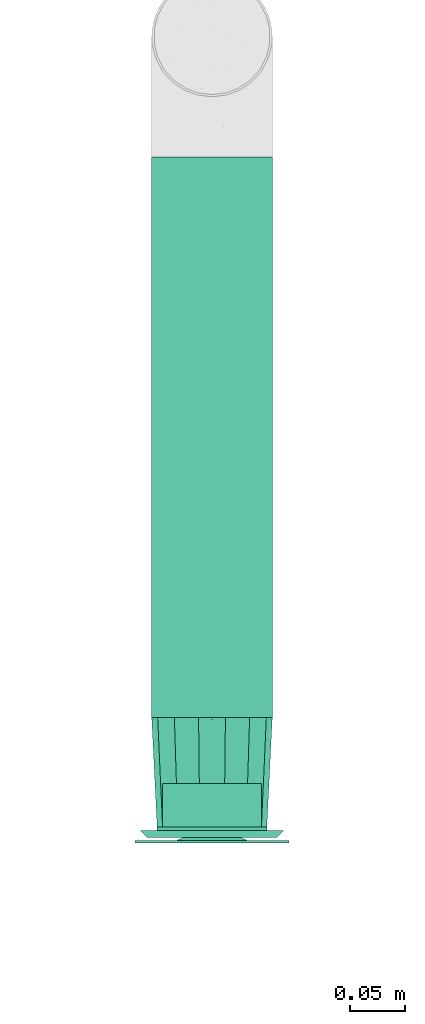
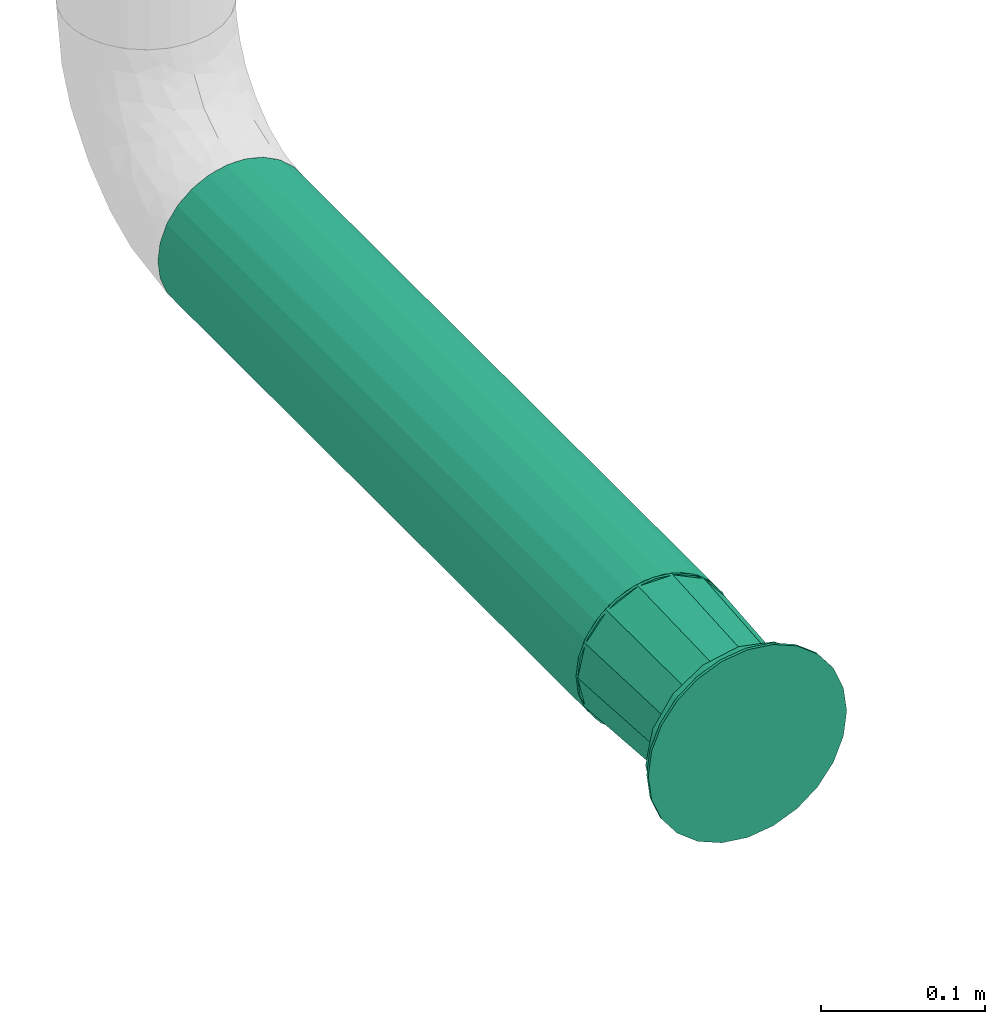
# One storey, part 100 of 115: 1 flow fitting, 1 flow segment, 1 flow terminal.
"""IFC2X3 building model written with IfcOpenShell, lengths in millimetres."""

from ifc_helpers import new_model, entity, si_unit, converted_unit, derived_unit, direction, frame, origin_with_axes, origin_2d_with_axis, place, context, subcontext, project, spatial, hollow_circle, extrude, open_shell, surface_model, source, transform, mapped, material, layer, layer_set, layer_usage, type_object, element, save


model = new_model("IFC2X3")

# Units and contexts
model_context = context("Model", 3, precision=1e-05, world=origin_with_axes(), true_north=direction((0.0, 1.0)))
body_context = subcontext(model_context, "Body", "Model", "MODEL_VIEW")
ifc_project = project(units=[si_unit("AREAUNIT", "SQUARE_METRE"), si_unit("VOLUMEUNIT", "CUBIC_METRE", prefix="DECI"), si_unit("TIMEUNIT", "SECOND"), si_unit("THERMODYNAMICTEMPERATUREUNIT", "DEGREE_CELSIUS"), si_unit("PRESSUREUNIT", "PASCAL"), si_unit("MASSUNIT", "GRAM", prefix="KILO"), si_unit("LENGTHUNIT", "METRE", prefix="MILLI"), si_unit("POWERUNIT", "WATT"), si_unit("ELECTRICCURRENTUNIT", "AMPERE"), si_unit("ELECTRICVOLTAGEUNIT", "VOLT"), derived_unit("VOLUMETRICFLOWRATEUNIT", [(si_unit("VOLUMEUNIT", "CUBIC_METRE", prefix="DECI"), 1), (si_unit("TIMEUNIT", "SECOND"), -1)]), derived_unit("LINEARVELOCITYUNIT", [(si_unit("LENGTHUNIT", "METRE"), 1), (si_unit("TIMEUNIT", "SECOND"), -1)]), derived_unit("MASSDENSITYUNIT", [(si_unit("MASSUNIT", "GRAM", prefix="KILO"), 1), (si_unit("VOLUMEUNIT", "CUBIC_METRE"), -1)]), converted_unit("PLANEANGLEUNIT", "DEGREE", entity("IfcRatioMeasure", 0.01745), si_unit("PLANEANGLEUNIT", "RADIAN"), dimensions=[0, 0, 0, 0, 0, 0, 0])], contexts=[model_context])

# Site, building, storey
site_placement = place(None, origin_with_axes())
site = spatial("IfcSite", under=ifc_project, at=site_placement, CompositionType="ELEMENT")
building_placement = place(site_placement, origin_with_axes())
building = spatial("IfcBuilding", under=site, at=building_placement, Name="mc-building", CompositionType="ELEMENT")
storey_placement = place(building_placement, frame((0.0, 0.0, 2950.0), z_axis=(0.0, 0.0, 1.0), x_axis=(1.0, 0.0, 0.0)))
storey = spatial("IfcBuildingStorey", under=building, at=storey_placement, Name="2. Korrus", CompositionType="ELEMENT", Elevation=2950.0)

# Flow terminal
air_terminal_type = type_object("IfcAirTerminalType", Name="100", PredefinedType="NOTDEFINED")
shared_shape_1 = source(origin_with_axes(), body_context, "Body", "SurfaceModel", [
    surface_model("IfcShellBasedSurfaceModel", [(11.2, 18.11733, -67.61481), (11.2, -18.11733, -67.61481), (11.2, 0.0, -70.0), (11.2, 67.61481, -18.11733), (11.2, 35.0, -60.62178), (11.2, 49.49747, -49.49747), (11.2, 60.62178, -35.0), (11.2, -67.61481, 18.11733), (11.2, -49.49747, -49.49747), (11.2, -67.61481, -18.11733), (11.2, -35.0, -60.62178), (11.2, -60.62178, -35.0), (11.2, -70.0, 0.0), (11.2, 18.11733, 67.61481), (11.2, 70.0, 0.0), (11.2, 67.61481, 18.11733), (11.2, 49.49747, 49.49747), (11.2, 60.62178, 35.0), (11.2, 35.0, 60.62178), (11.2, -49.49747, 49.49747), (11.2, -60.62178, 35.0), (11.2, -35.0, 60.62178), (11.2, -18.11733, 67.61481), (11.2, 0.0, 70.0), (9.2, 18.11733, 67.61481), (9.2, -67.61481, 18.11733), (9.2, 0.0, 70.0), (9.2, 49.49747, 49.49747), (9.2, 35.0, 60.62178), (9.2, 60.62178, 35.0), (9.2, 67.61481, 18.11733), (9.2, -35.0, 60.62178), (9.2, -49.49747, 49.49747), (9.2, -18.11733, 67.61481), (9.2, -60.62178, 35.0), (9.2, -67.61481, -18.11733), (9.2, -70.0, 0.0), (9.2, 67.61481, -18.11733), (9.2, 18.11733, -67.61481), (9.2, 49.49747, -49.49747), (9.2, 60.62178, -35.0), (9.2, 35.0, -60.62178), (9.2, -18.11733, -67.61481), (9.2, -49.49747, -49.49747), (9.2, -60.62178, -35.0), (9.2, -35.0, -60.62178), (9.2, 0.0, -70.0), (9.2, 70.0, 0.0), (9.2, 32.75, 0.0), (9.2, -16.375, 28.36233), (9.2, -28.36233, 16.375), (9.2, 16.375, 28.36233), (9.2, 0.0, 32.75), (9.2, 28.36233, 16.375), (9.2, -32.75, 0.0), (9.2, -16.375, -28.36233), (9.2, 16.375, -28.36233), (9.2, 0.0, -32.75), (9.2, 28.36233, -16.375), (9.2, -28.36233, -16.375), (6.2, -21.19625, -15.39997), (6.2, -21.19625, 15.39997), (6.2, 8.09625, 24.91768), (6.2, -8.09625, 24.91768), (6.2, -26.2, 0.0), (6.2, 21.19625, 15.39997), (6.2, -8.09625, -24.91768), (6.2, 21.19625, -15.39997), (6.2, 8.09625, -24.91768), (6.2, 26.2, 0.0), (9.2, 31.06579, -6.28555), (6.2, 23.69812, -7.69999), (6.2, -14.64625, -20.15883), (9.2, -22.36867, -22.36867), (6.2, -23.69812, -7.69999), (9.2, -31.06579, -6.28555), (6.2, 14.64625, -20.15883), (9.2, 8.1875, -30.55617), (6.2, 0.0, -24.91768), (9.2, 22.36867, -22.36867), (9.2, -8.1875, -30.55617), (9.2, -31.06579, 6.28555), (6.2, -23.69812, 7.69999), (6.2, 14.64625, 20.15883), (9.2, 22.36867, 22.36867), (6.2, 23.69812, 7.69999), (9.2, 31.06579, 6.28555), (6.2, -14.64625, 20.15883), (9.2, -8.1875, 30.55617), (6.2, 0.0, 24.91768), (9.2, -22.36867, 22.36867), (9.2, 8.1875, 30.55617), (6.2, -13.11761, 57.472), (6.2, -36.75472, 46.08897), (6.2, -53.11211, 25.57744), (6.2, 36.75472, 46.08897), (6.2, -58.95, 0.0), (6.2, 13.11761, 57.472), (6.2, 53.11211, 25.57744), (6.2, -53.11211, -25.57744), (6.2, -36.75472, -46.08897), (6.2, -13.11761, -57.472), (6.2, 58.95, 0.0), (6.2, 53.11211, -25.57744), (6.2, 13.11761, -57.472), (6.2, 36.75472, -46.08897), (0.0, -60.51411, 25.06576), (0.0, 0.0, 65.5), (0.0, 25.06576, 60.51411), (0.0, 46.3155, 46.3155), (0.0, 60.51411, 25.06576), (0.0, -46.3155, 46.3155), (0.0, -25.06576, 60.51411), (0.0, 0.0, -65.5), (0.0, -65.5, 0.0), (0.0, 65.5, 0.0), (0.0, 60.51411, -25.06576), (0.0, 46.3155, -46.3155), (0.0, 25.06576, -60.51411), (0.0, -46.3155, -46.3155), (0.0, -60.51411, -25.06576), (0.0, -25.06576, -60.51411), (6.2, 56.03105, -12.78872), (0.0, 53.4148, -35.69063), (0.0, 35.69063, -53.4148), (6.2, 24.93616, -51.78048), (0.0, -12.53288, -63.00706), (6.2, 0.0, -57.472), (0.0, -35.69063, -53.4148), (0.0, 63.00706, -12.53288), (6.2, 44.93342, -35.83321), (6.2, -24.93616, -51.78048), (6.2, -44.93342, -35.83321), (0.0, -53.4148, -35.69063), (0.0, 12.53288, -63.00706), (6.2, -56.03105, -12.78872), (0.0, -63.00706, -12.53288), (6.2, -56.03105, 12.78872), (0.0, -53.4148, 35.69063), (0.0, -35.69063, 53.4148), (6.2, -24.93616, 51.78048), (0.0, 12.53288, 63.00706), (6.2, 0.0, 57.472), (0.0, 35.69063, 53.4148), (0.0, -63.00706, 12.53288), (6.2, -44.93342, 35.83321), (6.2, 24.93616, 51.78048), (6.2, 44.93342, 35.83321), (0.0, 53.4148, 35.69063), (0.0, -12.53288, 63.00706), (6.2, 56.03105, 12.78872), (0.0, 63.00706, 12.53288), (-3.1, 12.94095, 48.29629), (-3.1, -35.35534, 35.35534), (-3.1, 0.0, 50.0), (-3.1, 35.35534, 35.35534), (-3.1, 25.0, 43.30127), (-3.1, -43.30127, 25.0), (-3.1, 43.30127, 25.0), (-3.1, -48.29629, -12.94095), (-3.1, -12.94095, 48.29629), (-3.1, -25.0, 43.30127), (-3.1, -50.0, 0.0), (-3.1, -48.29629, 12.94095), (-3.1, 48.29629, 12.94095), (-3.1, 12.94095, -48.29629), (-3.1, 50.0, 0.0), (-3.1, 48.29629, -12.94095), (-3.1, 35.35534, -35.35534), (-3.1, 43.30127, -25.0), (-3.1, 25.0, -43.30127), (-3.1, 0.0, -50.0), (-3.1, -35.35534, -35.35534), (-3.1, -43.30127, -25.0), (-3.1, -25.0, -43.30127), (-3.1, -12.94095, -48.29629), (0.0, 25.0, -43.30127), (0.0, 0.0, -50.0), (0.0, 12.94095, -48.29629), (0.0, 48.29629, -12.94095), (0.0, 35.35534, -35.35534), (0.0, -25.0, -43.30127), (0.0, 43.30127, -25.0), (0.0, -50.0, 0.0), (0.0, -12.94095, -48.29629), (0.0, -35.35534, -35.35534), (0.0, -48.29629, -12.94095), (0.0, -43.30127, -25.0), (0.0, 50.0, 0.0), (0.0, 43.30127, 25.0), (0.0, 12.94095, 48.29629), (0.0, 35.35534, 35.35534), (0.0, 25.0, 43.30127), (0.0, 0.0, 50.0), (0.0, -35.35534, 35.35534), (0.0, -43.30127, 25.0), (0.0, -48.29629, 12.94095), (0.0, -12.94095, 48.29629), (0.0, -25.0, 43.30127), (0.0, 48.29629, 12.94095), (-43.1, 0.0, 45.0), (-43.1, 11.64686, 43.46666), (-43.1, 22.5, 38.97115), (-43.1, -11.64686, 43.46666), (-43.1, 38.97115, 22.5), (-43.1, 43.46666, 11.64686), (-43.1, 31.81981, 31.81981), (-43.1, -22.5, 38.97115), (-43.1, -43.46666, 11.64686), (-43.1, -31.81981, 31.81981), (-43.1, -38.97115, 22.5), (-43.1, -45.0, 0.0), (-43.1, -43.46666, -11.64686), (-43.1, 45.0, 0.0), (-43.1, 43.46666, -11.64686), (-43.1, 38.97115, -22.5), (-43.1, 31.81981, -31.81981), (-43.1, 22.5, -38.97115), (-43.1, 11.64686, -43.46666), (-43.1, -31.81981, -31.81981), (-43.1, -38.97115, -22.5), (-43.1, -22.5, -38.97115), (-43.1, 0.0, -45.0), (-43.1, -11.64686, -43.46666), (-3.1, 22.5, -38.97115), (-3.1, 0.0, -45.0), (-3.1, 11.64686, -43.46666), (-3.1, 31.81981, -31.81981), (-3.1, -22.5, -38.97115), (-3.1, 38.97115, -22.5), (-3.1, 43.46666, -11.64686), (-3.1, 45.0, 0.0), (-3.1, -45.0, 0.0), (-3.1, -11.64686, -43.46666), (-3.1, -31.81981, -31.81981), (-3.1, -43.46666, -11.64686), (-3.1, -38.97115, -22.5), (-3.1, 0.0, 45.0), (-3.1, 43.46666, 11.64686), (-3.1, 38.97115, 22.5), (-3.1, 22.5, 38.97115), (-3.1, 31.81981, 31.81981), (-3.1, 11.64686, 43.46666), (-3.1, -11.64686, 43.46666), (-3.1, -43.46666, 11.64686), (-3.1, -31.81981, 31.81981), (-3.1, -38.97115, 22.5), (-3.1, -22.5, 38.97115)], [open_shell([[[0, 1, 2]], [[3, 0, 4]], [[5, 6, 3]], [[5, 3, 4]], [[7, 1, 0]], [[8, 7, 9]], [[10, 7, 8]], [[8, 9, 11]], [[12, 9, 7]], [[1, 7, 10]], [[7, 0, 3]], [[13, 14, 15]], [[16, 15, 17]], [[16, 18, 13]], [[16, 13, 15]], [[14, 13, 7]], [[7, 19, 20]], [[19, 7, 21]], [[7, 22, 21]], [[22, 7, 23]], [[7, 13, 23]], [[14, 7, 3]], [[24, 25, 26]], [[27, 24, 28]], [[27, 29, 30]], [[27, 30, 24]], [[25, 24, 30]], [[31, 25, 32]], [[25, 31, 33]], [[32, 25, 34]], [[33, 26, 25]], [[25, 35, 36]], [[25, 30, 37]], [[25, 37, 38]], [[39, 37, 40]], [[39, 41, 38]], [[39, 38, 37]], [[38, 42, 25]], [[35, 43, 44]], [[35, 25, 43]], [[45, 43, 25]], [[42, 45, 25]], [[38, 46, 42]], [[37, 30, 47]], [[35, 9, 36]], [[44, 11, 35]], [[10, 43, 45]], [[44, 43, 8]], [[1, 45, 42]], [[35, 11, 9]], [[9, 12, 36]], [[1, 10, 45]], [[8, 43, 10]], [[8, 11, 44]], [[2, 1, 42]], [[42, 46, 2]], [[38, 0, 46]], [[41, 4, 38]], [[6, 39, 40]], [[41, 39, 5]], [[3, 40, 37]], [[41, 5, 4]], [[4, 0, 38]], [[14, 3, 37]], [[6, 40, 3]], [[6, 5, 39]], [[47, 14, 37]], [[46, 0, 2]], [[30, 15, 47]], [[29, 17, 30]], [[18, 27, 28]], [[29, 27, 16]], [[13, 28, 24]], [[30, 17, 15]], [[15, 14, 47]], [[13, 18, 28]], [[16, 27, 18]], [[16, 17, 29]], [[23, 13, 24]], [[24, 26, 23]], [[33, 22, 26]], [[31, 21, 33]], [[20, 32, 34]], [[31, 32, 19]], [[7, 34, 25]], [[31, 19, 21]], [[21, 22, 33]], [[12, 7, 25]], [[20, 34, 7]], [[20, 19, 32]], [[36, 12, 25]], [[26, 22, 23]], [[48, 49, 50]], [[48, 51, 49]], [[49, 51, 52]], [[53, 51, 48]], [[48, 50, 54]], [[54, 55, 48]], [[56, 55, 57]], [[55, 58, 48]], [[58, 55, 56]], [[55, 54, 59]], [[60, 61, 62]], [[62, 61, 63]], [[64, 61, 60]], [[62, 65, 66]], [[67, 68, 65]], [[66, 60, 62]], [[65, 68, 66]], [[69, 67, 65]], [[69, 48, 70]], [[58, 71, 70]], [[72, 73, 60]], [[59, 74, 60]], [[75, 64, 74]], [[56, 68, 76]], [[72, 66, 55]], [[73, 72, 55]], [[68, 77, 78]], [[64, 75, 54]], [[59, 75, 74]], [[70, 71, 69]], [[67, 79, 76]], [[80, 55, 66]], [[68, 56, 77]], [[56, 76, 79]], [[79, 67, 58]], [[71, 58, 67]], [[80, 78, 57]], [[77, 57, 78]], [[66, 78, 80]], [[59, 60, 73]], [[64, 54, 81]], [[50, 82, 81]], [[83, 84, 65]], [[53, 85, 65]], [[86, 69, 85]], [[49, 63, 87]], [[83, 62, 51]], [[84, 83, 51]], [[63, 88, 89]], [[69, 86, 48]], [[53, 86, 85]], [[81, 82, 64]], [[61, 90, 87]], [[91, 51, 62]], [[63, 49, 88]], [[49, 87, 90]], [[90, 61, 50]], [[82, 50, 61]], [[91, 89, 52]], [[88, 52, 89]], [[62, 89, 91]], [[53, 65, 84]], [[92, 93, 94]], [[95, 94, 96]], [[97, 92, 95]], [[95, 92, 94]], [[96, 98, 95]], [[96, 99, 98]], [[99, 100, 101]], [[101, 102, 98]], [[102, 101, 103]], [[104, 105, 103]], [[101, 104, 103]], [[101, 98, 99]], [[106, 107, 108]], [[109, 110, 108]], [[106, 108, 110]], [[111, 112, 106]], [[106, 112, 107]], [[106, 113, 114]], [[106, 110, 113]], [[115, 116, 117]], [[117, 113, 110]], [[113, 117, 118]], [[114, 119, 120]], [[121, 119, 114]], [[121, 114, 113]], [[115, 117, 110]], [[103, 116, 122]], [[123, 116, 103]], [[124, 125, 118]], [[101, 126, 127]], [[100, 119, 128]], [[102, 122, 129]], [[103, 130, 123]], [[102, 129, 115]], [[113, 127, 126]], [[125, 124, 105]], [[130, 105, 117]], [[118, 125, 104]], [[124, 117, 105]], [[131, 100, 128]], [[119, 100, 132]], [[133, 99, 120]], [[134, 118, 104]], [[122, 116, 129]], [[127, 134, 104]], [[131, 121, 101]], [[99, 133, 132]], [[128, 121, 131]], [[130, 117, 123]], [[101, 121, 126]], [[99, 135, 120]], [[96, 136, 135]], [[136, 120, 135]], [[134, 127, 113]], [[133, 119, 132]], [[136, 96, 114]], [[94, 106, 137]], [[138, 106, 94]], [[139, 140, 112]], [[97, 141, 142]], [[95, 109, 143]], [[96, 137, 144]], [[94, 145, 138]], [[96, 144, 114]], [[107, 142, 141]], [[140, 139, 93]], [[145, 93, 111]], [[112, 140, 92]], [[139, 111, 93]], [[146, 95, 143]], [[109, 95, 147]], [[148, 98, 110]], [[149, 112, 92]], [[137, 106, 144]], [[142, 149, 92]], [[146, 108, 97]], [[98, 148, 147]], [[143, 108, 146]], [[145, 111, 138]], [[97, 108, 141]], [[98, 150, 110]], [[102, 151, 150]], [[151, 110, 150]], [[149, 142, 107]], [[148, 109, 147]], [[151, 102, 115]], [[152, 153, 154]], [[155, 152, 156]], [[157, 152, 158]], [[158, 152, 155]], [[158, 159, 157]], [[160, 153, 161]], [[160, 154, 153]], [[157, 162, 163]], [[153, 152, 157]], [[157, 159, 162]], [[158, 164, 159]], [[165, 166, 167]], [[168, 167, 169]], [[170, 165, 167]], [[170, 167, 168]], [[166, 165, 171]], [[159, 172, 173]], [[172, 159, 174]], [[174, 171, 175]], [[159, 164, 174]], [[166, 171, 174]], [[174, 164, 166]], [[176, 177, 178]], [[179, 176, 180]], [[176, 179, 181]], [[179, 180, 182]], [[179, 183, 181]], [[177, 181, 184]], [[177, 176, 181]], [[185, 186, 187]], [[186, 185, 181]], [[181, 183, 186]], [[183, 179, 188]], [[183, 188, 189]], [[190, 189, 191]], [[189, 190, 183]], [[190, 191, 192]], [[193, 194, 190]], [[183, 195, 196]], [[183, 190, 195]], [[194, 197, 198]], [[194, 195, 190]], [[197, 194, 193]], [[189, 188, 199]], [[164, 199, 166]], [[158, 189, 164]], [[192, 155, 156]], [[158, 155, 191]], [[190, 156, 152]], [[164, 189, 199]], [[199, 188, 166]], [[190, 192, 156]], [[191, 155, 192]], [[191, 189, 158]], [[193, 190, 152]], [[152, 154, 193]], [[160, 197, 154]], [[161, 198, 160]], [[195, 153, 157]], [[161, 153, 194]], [[196, 157, 163]], [[161, 194, 198]], [[198, 197, 160]], [[183, 196, 163]], [[195, 157, 196]], [[195, 194, 153]], [[162, 183, 163]], [[154, 197, 193]], [[159, 186, 162]], [[173, 187, 159]], [[181, 172, 174]], [[173, 172, 185]], [[184, 174, 175]], [[159, 187, 186]], [[186, 183, 162]], [[184, 181, 174]], [[185, 172, 181]], [[185, 187, 173]], [[177, 184, 175]], [[175, 171, 177]], [[165, 178, 171]], [[170, 176, 165]], [[182, 168, 169]], [[170, 168, 180]], [[179, 169, 167]], [[170, 180, 176]], [[176, 178, 165]], [[188, 179, 167]], [[182, 169, 179]], [[182, 180, 168]], [[166, 188, 167]], [[171, 178, 177]], [[200, 201, 202]], [[203, 200, 202]], [[204, 205, 202]], [[204, 202, 206]], [[203, 202, 205]], [[207, 208, 209]], [[207, 203, 205]], [[209, 208, 210]], [[211, 208, 212]], [[208, 207, 212]], [[207, 205, 212]], [[213, 214, 215]], [[205, 215, 212]], [[212, 216, 217]], [[216, 212, 215]], [[218, 219, 217]], [[212, 219, 220]], [[212, 217, 219]], [[221, 222, 223]], [[222, 221, 219]], [[218, 222, 219]], [[215, 205, 213]], [[224, 225, 226]], [[227, 228, 224]], [[229, 230, 231]], [[228, 227, 229]], [[229, 232, 228]], [[225, 228, 233]], [[225, 224, 228]], [[234, 235, 236]], [[235, 234, 228]], [[228, 232, 235]], [[232, 229, 231]], [[237, 238, 239]], [[240, 239, 241]], [[240, 242, 237]], [[240, 237, 239]], [[238, 237, 243]], [[244, 245, 246]], [[247, 244, 232]], [[244, 247, 245]], [[232, 238, 247]], [[238, 243, 247]], [[238, 232, 231]], [[205, 238, 213]], [[204, 239, 205]], [[240, 206, 202]], [[204, 206, 241]], [[242, 202, 201]], [[205, 239, 238]], [[238, 231, 213]], [[240, 202, 242]], [[241, 206, 240]], [[241, 239, 204]], [[201, 237, 242]], [[201, 200, 237]], [[243, 203, 207]], [[209, 247, 207]], [[246, 210, 208]], [[209, 210, 245]], [[244, 208, 211]], [[203, 243, 200]], [[207, 247, 243]], [[200, 243, 237]], [[209, 245, 247]], [[210, 246, 245]], [[244, 246, 208]], [[211, 232, 244]], [[212, 235, 211]], [[220, 236, 212]], [[228, 219, 221]], [[220, 219, 234]], [[233, 221, 223]], [[212, 236, 235]], [[235, 232, 211]], [[233, 228, 221]], [[234, 219, 228]], [[234, 236, 220]], [[225, 233, 223]], [[223, 222, 225]], [[226, 218, 217]], [[216, 224, 217]], [[229, 215, 214]], [[216, 215, 227]], [[230, 214, 213]], [[218, 226, 222]], [[217, 224, 226]], [[222, 226, 225]], [[216, 227, 224]], [[215, 229, 227]], [[230, 229, 214]], [[213, 231, 230]]])]),
])
flow_terminal_placement = place(storey_placement, frame((30674.56773, 12939.66532, 2300.0), z_axis=(0.0, 0.0, 1.0), x_axis=(0.0, -1.0, 0.0)))
element("IfcFlowTerminal", 1, at=flow_terminal_placement, inside=storey, type_object=air_terminal_type, Name="100", context=body_context, shape_type="MappedRepresentation", body=[
    mapped(shared_shape_1, transform((0.0, 0.0, 0.0), scale=1.0)),
])

# Flow segment
ifc_material = material(Name="FZ1")
ifc_layer = layer(ifc_material, 0.0)
ifc_layer_set = layer_set([ifc_layer], Name="FZ1")
ifc_layer_usage = layer_usage(ifc_layer_set, "AXIS1", "POSITIVE", 0.0)
duct_segment_type = type_object("IfcDuctSegmentType", PredefinedType="RIGIDSEGMENT")
shared_shape_2 = source(origin_with_axes(), body_context, "Body", "SweptSolid", [
    extrude(hollow_circle(Radius=55.0, WallThickness=2.0, at=origin_2d_with_axis()), frame((0.0, 0.0, 0.0), z_axis=(1.0, 0.0, 0.0), x_axis=(0.0, 1.0, 0.0)), (0.0, 0.0, 1.0), 510.8),
])
flow_segment_placement = place(storey_placement, frame((30674.56773, 13042.76532, 2300.0), z_axis=(0.0, 0.0, 1.0), x_axis=(0.0, 1.0, 0.0)))
element("IfcFlowSegment", 2, at=flow_segment_placement, inside=storey, type_object=duct_segment_type, material=ifc_layer_usage, context=body_context, shape_type="MappedRepresentation", body=[
    mapped(shared_shape_2, transform((0.0, 0.0, 0.0), scale=1.0)),
])

# Flow fitting
duct_fitting_type = type_object("IfcDuctFittingType", PredefinedType="TRANSITION")
shared_shape_3 = source(origin_with_axes(), body_context, "Body", "SurfaceModel", [
    surface_model("IfcShellBasedSurfaceModel", [(0.0, 12.94095, 48.29629), (0.0, -35.35534, 35.35534), (0.0, 0.0, 50.0), (0.0, 35.35534, 35.35534), (0.0, 25.0, 43.30127), (0.0, 43.30127, 25.0), (0.0, 48.29629, 12.94095), (0.0, -12.94095, 48.29629), (0.0, -25.0, 43.30127), (0.0, -48.29629, 12.94095), (0.0, -43.30127, 25.0), (0.0, -25.0, -43.30127), (0.0, -48.29629, -12.94095), (0.0, -50.0, 0.0), (0.0, 48.29629, -12.94095), (0.0, 12.94095, -48.29629), (0.0, 43.30127, -25.0), (0.0, 35.35534, -35.35534), (0.0, 25.0, -43.30127), (0.0, -35.35534, -35.35534), (0.0, -43.30127, -25.0), (0.0, -12.94095, -48.29629), (0.0, 0.0, -50.0), (0.0, 50.0, 0.0), (100.0, -55.0, 0.0), (100.0, -12.23865, 53.62104), (100.0, -34.29194, 43.00073), (100.0, 49.55329, -23.86361), (100.0, 12.23865, 53.62104), (100.0, 34.29194, 43.00073), (100.0, 55.0, 0.0), (100.0, 49.55329, 23.86361), (100.0, -49.55329, 23.86361), (100.0, 12.23865, -53.62104), (100.0, -49.55329, -23.86361), (100.0, -34.29194, -43.00073), (100.0, 34.29194, -43.00073), (100.0, -12.23865, -53.62104), (0.0, 11.12605, 48.7464), (0.0, -11.12605, 48.7464), (0.0, 31.17449, 39.09157), (0.0, -45.04844, -21.69419), (0.0, -45.04844, 21.69419), (0.0, -31.17449, 39.09157), (0.0, 45.04844, 21.69419), (0.0, 45.04844, -21.69419), (0.0, 31.17449, -39.09157), (0.0, -31.17449, -39.09157), (0.0, -11.12605, -48.7464), (0.0, 11.12605, -48.7464), (0.0, -47.52422, -10.84709), (100.0, -41.92261, -33.43217), (0.0, -38.11147, -30.39288), (100.0, 41.92261, -33.43217), (0.0, 38.11147, -30.39288), (0.0, -21.15027, -43.91899), (100.0, -23.2653, -48.31088), (100.0, -52.32388, -11.72483), (100.0, 0.0, -53.62104), (0.0, 0.0, -48.7464), (100.0, 23.2653, -48.31088), (0.0, 21.15027, -43.91899), (100.0, 52.32388, -11.72483), (0.0, 47.52422, -10.84709), (0.0, 47.52422, 10.84709), (100.0, 41.92261, 33.43217), (0.0, 38.11147, 30.39288), (100.0, -41.92261, 33.43217), (0.0, -38.11147, 30.39288), (0.0, 21.15027, 43.91899), (100.0, 23.2653, 48.31088), (100.0, 52.32388, 11.72483), (100.0, 0.0, 53.62104), (0.0, 0.0, 48.7464), (100.0, -23.2653, 48.31088), (0.0, -21.15027, 43.91899), (100.0, -52.32388, 11.72483), (0.0, -47.52422, 10.84709), (100.0, 27.5, -47.63139), (100.0, 0.0, -55.0), (100.0, 14.23505, -53.12592), (100.0, 38.89087, -38.89087), (100.0, -27.5, -47.63139), (100.0, 47.63139, -27.5), (100.0, 53.12592, -14.23505), (100.0, -14.23505, -53.12592), (100.0, -47.63139, -27.5), (100.0, -38.89087, -38.89087), (100.0, -53.12592, -14.23505), (100.0, 53.12592, 14.23505), (100.0, 47.63139, 27.5), (100.0, 27.5, 47.63139), (100.0, 38.89087, 38.89087), (100.0, 14.23505, 53.12592), (100.0, 0.0, 55.0), (100.0, -47.63139, 27.5), (100.0, -53.12592, 14.23505), (100.0, -27.5, 47.63139), (100.0, -38.89087, 38.89087), (100.0, -14.23505, 53.12592), (98.0, 0.0, 55.0), (98.0, 14.23505, 53.12592), (98.0, 27.5, 47.63139), (98.0, 38.89087, 38.89087), (98.0, 47.63139, 27.5), (98.0, -47.63139, 27.5), (98.0, 53.12592, -14.23505), (98.0, -27.5, 47.63139), (98.0, -14.23505, 53.12592), (98.0, -38.89087, 38.89087), (98.0, -55.0, 0.0), (98.0, -53.12592, 14.23505), (98.0, 53.12592, 14.23505), (98.0, 47.63139, -27.5), (98.0, -27.5, -47.63139), (98.0, 0.0, -55.0), (98.0, 38.89087, -38.89087), (98.0, 27.5, -47.63139), (98.0, 14.23505, -53.12592), (98.0, -47.63139, -27.5), (98.0, -38.89087, -38.89087), (98.0, -53.12592, -14.23505), (98.0, -14.23505, -53.12592), (98.0, 55.0, 0.0), (2.0, 12.94095, -48.29629), (2.0, 25.0, -43.30127), (2.0, 35.35534, -35.35534), (2.0, 43.30127, -25.0), (2.0, 48.29629, -12.94095), (2.0, 0.0, -50.0), (2.0, 50.0, 0.0), (2.0, -25.0, -43.30127), (2.0, -12.94095, -48.29629), (2.0, -35.35534, -35.35534), (2.0, -48.29629, -12.94095), (2.0, -43.30127, -25.0), (2.0, -48.29629, 12.94095), (2.0, 48.29629, 12.94095), (2.0, 43.30127, 25.0), (2.0, 35.35534, 35.35534), (2.0, -35.35534, 35.35534), (2.0, 12.94095, 48.29629), (2.0, 25.0, 43.30127), (2.0, 0.0, 50.0), (2.0, -43.30127, 25.0), (2.0, -50.0, 0.0), (2.0, -12.94095, 48.29629), (2.0, -25.0, 43.30127)], [open_shell([[[0, 1, 2]], [[3, 0, 4]], [[3, 5, 6]], [[0, 3, 1]], [[6, 1, 3]], [[7, 1, 8]], [[7, 2, 1]], [[1, 9, 10]], [[9, 1, 11]], [[12, 13, 9]], [[11, 1, 6]], [[6, 14, 11]], [[15, 14, 16]], [[17, 18, 15]], [[17, 15, 16]], [[11, 14, 15]], [[12, 19, 20]], [[19, 12, 11]], [[15, 21, 11]], [[12, 9, 11]], [[22, 21, 15]], [[14, 6, 23]], [[24, 25, 26]], [[25, 27, 28]], [[29, 28, 27]], [[27, 30, 31]], [[31, 29, 27]], [[24, 26, 32]], [[33, 24, 34]], [[33, 34, 35]], [[36, 27, 33]], [[33, 27, 24]], [[35, 37, 33]], [[24, 27, 25]], [[38, 23, 39]], [[40, 23, 38]], [[41, 42, 43]], [[41, 13, 42]], [[23, 43, 39]], [[40, 44, 23]], [[41, 23, 45]], [[41, 45, 46]], [[47, 41, 48]], [[49, 48, 41]], [[41, 46, 49]], [[23, 41, 43]], [[34, 50, 41]], [[47, 51, 52]], [[45, 27, 53]], [[36, 54, 53]], [[55, 48, 56]], [[34, 57, 50]], [[57, 13, 50]], [[13, 57, 24]], [[55, 35, 47]], [[35, 51, 47]], [[51, 41, 52]], [[58, 59, 49]], [[60, 61, 46]], [[37, 59, 58]], [[62, 63, 23]], [[35, 55, 56]], [[23, 30, 62]], [[53, 54, 45]], [[48, 37, 56]], [[33, 49, 61]], [[49, 33, 58]], [[54, 36, 46]], [[63, 27, 45]], [[34, 41, 51]], [[33, 61, 60]], [[48, 59, 37]], [[27, 63, 62]], [[46, 36, 60]], [[31, 64, 44]], [[40, 65, 66]], [[42, 32, 67]], [[26, 68, 67]], [[69, 38, 70]], [[31, 71, 64]], [[71, 23, 64]], [[23, 71, 30]], [[69, 29, 40]], [[29, 65, 40]], [[65, 44, 66]], [[72, 73, 39]], [[74, 75, 43]], [[28, 73, 72]], [[76, 77, 13]], [[29, 69, 70]], [[13, 24, 76]], [[67, 68, 42]], [[38, 28, 70]], [[25, 39, 75]], [[39, 25, 72]], [[68, 26, 43]], [[77, 32, 42]], [[31, 44, 65]], [[25, 75, 74]], [[38, 73, 28]], [[32, 77, 76]], [[43, 26, 74]], [[78, 79, 80]], [[81, 82, 78]], [[82, 83, 84]], [[81, 83, 82]], [[30, 82, 84]], [[79, 82, 85]], [[79, 78, 82]], [[82, 86, 87]], [[82, 30, 86]], [[24, 88, 86]], [[86, 30, 89]], [[90, 24, 89]], [[91, 90, 92]], [[91, 93, 94]], [[90, 91, 24]], [[94, 95, 91]], [[24, 95, 96]], [[24, 91, 95]], [[94, 97, 98]], [[98, 95, 94]], [[97, 94, 99]], [[89, 24, 86]], [[100, 101, 102]], [[100, 102, 103]], [[100, 104, 105]], [[104, 100, 103]], [[106, 105, 104]], [[100, 107, 108]], [[100, 109, 107]], [[105, 110, 111]], [[109, 100, 105]], [[105, 106, 110]], [[106, 104, 112]], [[106, 113, 110]], [[113, 114, 110]], [[115, 116, 117]], [[113, 116, 115]], [[117, 118, 115]], [[119, 114, 120]], [[121, 110, 119]], [[114, 115, 122]], [[119, 110, 114]], [[115, 114, 113]], [[123, 106, 112]], [[121, 88, 110]], [[119, 86, 121]], [[82, 120, 114]], [[119, 120, 87]], [[85, 114, 122]], [[121, 86, 88]], [[88, 24, 110]], [[85, 82, 114]], [[87, 120, 82]], [[87, 86, 119]], [[79, 85, 122]], [[122, 115, 79]], [[118, 80, 115]], [[117, 78, 118]], [[83, 116, 113]], [[117, 116, 81]], [[84, 113, 106]], [[117, 81, 78]], [[78, 80, 118]], [[30, 84, 106]], [[83, 113, 84]], [[83, 81, 116]], [[123, 30, 106]], [[115, 80, 79]], [[112, 89, 123]], [[104, 90, 112]], [[91, 103, 102]], [[104, 103, 92]], [[93, 102, 101]], [[112, 90, 89]], [[89, 30, 123]], [[93, 91, 102]], [[92, 103, 91]], [[92, 90, 104]], [[94, 93, 101]], [[101, 100, 94]], [[108, 99, 100]], [[107, 97, 108]], [[95, 109, 105]], [[107, 109, 98]], [[96, 105, 111]], [[107, 98, 97]], [[97, 99, 108]], [[24, 96, 111]], [[95, 105, 96]], [[95, 98, 109]], [[110, 24, 111]], [[100, 99, 94]], [[124, 125, 126]], [[124, 126, 127]], [[124, 128, 129]], [[128, 124, 127]], [[129, 128, 130]], [[129, 131, 132]], [[129, 130, 131]], [[133, 134, 135]], [[134, 133, 131]], [[131, 136, 134]], [[131, 130, 137]], [[137, 138, 139]], [[140, 137, 139]], [[140, 139, 141]], [[141, 139, 142]], [[140, 141, 143]], [[136, 140, 144]], [[145, 134, 136]], [[140, 146, 147]], [[131, 140, 136]], [[143, 146, 140]], [[131, 137, 140]], [[12, 134, 13]], [[20, 135, 12]], [[131, 19, 11]], [[20, 19, 133]], [[132, 11, 21]], [[12, 135, 134]], [[134, 145, 13]], [[132, 131, 11]], [[133, 19, 131]], [[133, 135, 20]], [[129, 132, 21]], [[21, 22, 129]], [[15, 124, 22]], [[18, 125, 15]], [[127, 17, 16]], [[18, 17, 126]], [[128, 16, 14]], [[18, 126, 125]], [[125, 124, 15]], [[130, 128, 14]], [[127, 16, 128]], [[127, 126, 17]], [[23, 130, 14]], [[22, 124, 129]], [[6, 137, 23]], [[5, 138, 6]], [[142, 3, 4]], [[5, 3, 139]], [[141, 4, 0]], [[6, 138, 137]], [[137, 130, 23]], [[141, 142, 4]], [[139, 3, 142]], [[139, 138, 5]], [[143, 141, 0]], [[0, 2, 143]], [[7, 146, 2]], [[8, 147, 7]], [[144, 1, 10]], [[8, 1, 140]], [[136, 10, 9]], [[8, 140, 147]], [[147, 146, 7]], [[145, 136, 9]], [[144, 10, 136]], [[144, 140, 1]], [[13, 145, 9]], [[2, 146, 143]]])]),
])
flow_fitting_placement = place(storey_placement, frame((30674.56773, 12942.76532, 2300.0), z_axis=(0.0, 0.0, 1.0), x_axis=(0.0, 1.0, 0.0)))
element("IfcFlowFitting", 3, at=flow_fitting_placement, inside=storey, type_object=duct_fitting_type, context=body_context, shape_type="MappedRepresentation", body=[
    mapped(shared_shape_3, transform((0.0, 0.0, 0.0), scale=1.0)),
])

save(model, "model.ifc")
